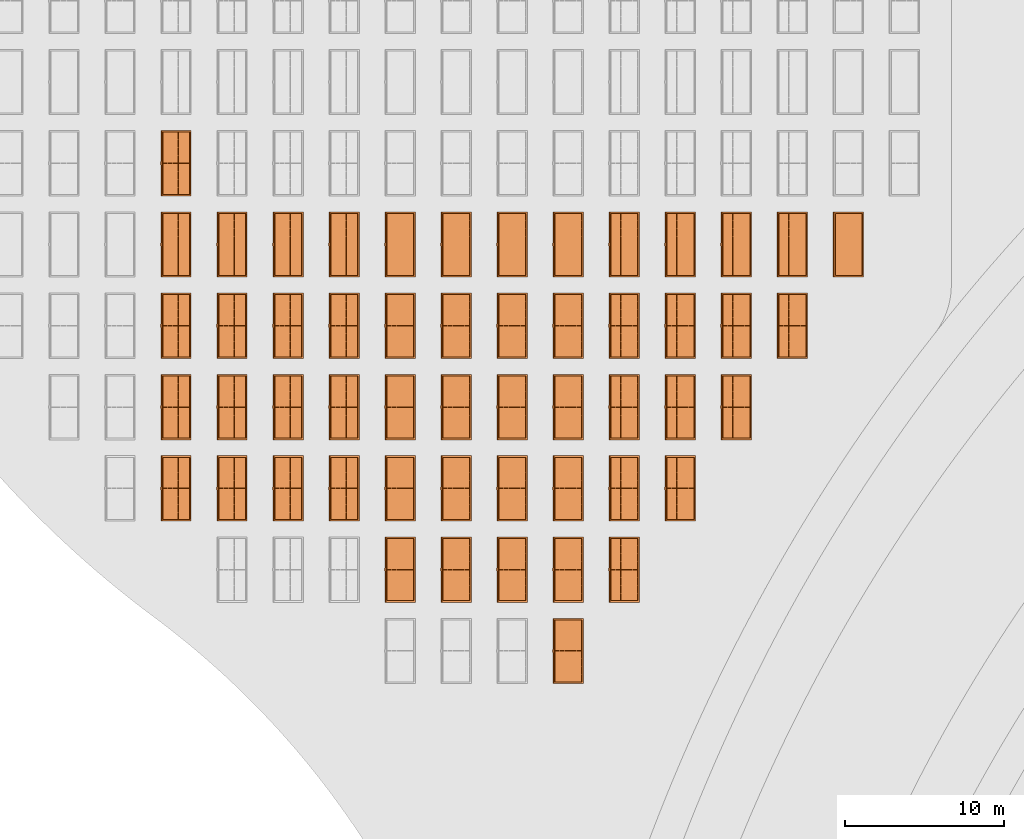
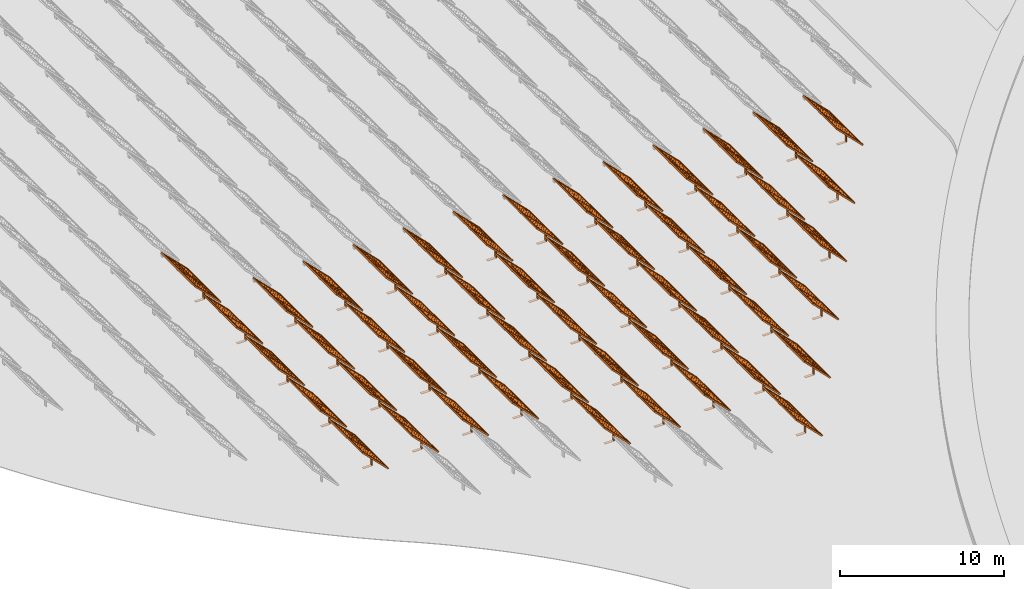
# One storey, part 16 of 39: 53 proxies.
"""IFC2X3 building model written with IfcOpenShell, lengths in millimetres."""

from ifc_helpers import new_model, entity, si_unit, converted_unit, derived_unit, direction, frame, frame_2d, origin, origin_2d_with_axis, place, context, subcontext, project, spatial, polyline, rectangle, outline, extrude, source, transform, mapped, material, material_list, element, save


model = new_model("IFC2X3")

# Units and contexts
model_context = context("Model", 3, precision=1e-06, world=origin(), true_north=direction((2.0, 6.12303176911189e-17, 1.0)))
context_of_model = context(None, 3, precision=1e-06, world=origin(), true_north=direction((2.0, 6.12303176911189e-17, 1.0)))
body_context = subcontext(model_context, "Body", "Model", "MODEL_VIEW")
ifc_project = project(units=[si_unit("LENGTHUNIT", "METRE", prefix="MILLI"), si_unit("AREAUNIT", "SQUARE_METRE", prefix="MILLI"), si_unit("VOLUMEUNIT", "CUBIC_METRE", prefix="MILLI"), converted_unit("PLANEANGLEUNIT", "DEGREE", entity("IfcRatioMeasure", 0.0174532925199433), si_unit("PLANEANGLEUNIT", "RADIAN"), dimensions=[0, 0, 0, 0, 0, 0, 0]), si_unit("MASSUNIT", "GRAM", prefix="KILO"), si_unit("TIMEUNIT", "SECOND"), si_unit("THERMODYNAMICTEMPERATUREUNIT", "KELVIN"), derived_unit("THERMALTRANSMITTANCEUNIT", [(si_unit("MASSUNIT", "GRAM", prefix="KILO"), 1), (si_unit("THERMODYNAMICTEMPERATUREUNIT", "KELVIN"), -1), (si_unit("TIMEUNIT", "SECOND"), -3)]), derived_unit("VOLUMETRICFLOWRATEUNIT", [(si_unit("LENGTHUNIT", "METRE"), 3), (si_unit("TIMEUNIT", "SECOND"), -1)])], contexts=[model_context, context_of_model])

# Site, building, storey
site_placement = place(None, origin())
site = spatial("IfcSite", under=ifc_project, at=site_placement, CompositionType="ELEMENT")
building_placement = place(site_placement, origin())
building = spatial("IfcBuilding", under=site, at=building_placement, CompositionType="ELEMENT")
storey_placement = place(building_placement, frame((0.0, 0.0, 4000.0)))
storey = spatial("IfcBuildingStorey", under=building, at=storey_placement, Name="Level 2", CompositionType="ELEMENT", Elevation=4000.0)

# Proxies
ifc_material_1 = material(Name="Stand-Steel")
ifc_material_2 = material(Name="Aluminium")
ifc_material_3 = material(Name="Glass")
ifc_material_list_1 = material_list([ifc_material_1, ifc_material_2, ifc_material_3])
shared_shape = source(origin(), body_context, "Body", "SweptSolid", [
    extrude(outline(polyline([(-629.526235435404, -220.0), (329.763117717702, -220.0), (329.763117717703, 410.0), (299.763117717703, 410.0), (299.763117717702, -190.0), (-629.526235435404, -190.0), (-629.526235435404, -220.0)])), frame((-190.00003127179, -100.0, 299.763117717707), z_axis=(0.0, 1.0, 0.0), x_axis=(0.0, 0.0, -1.0)), (0.0, 0.0, 1.0), 200.0),
    extrude(rectangle(XDim=20.0000000000001, YDim=200.0, at=frame_2d((0.0, -7.105427357601e-14), x_axis=(0.0, 1.0))), frame((-7.07109908365613, 0.0, 922.21828534124), z_axis=(-0.70710678118654, 0.0, 0.707106781186555), x_axis=(0.0, 1.0, 0.0)), (0.0, 0.0, 1.0), 2600.0),
    extrude(rectangle(XDim=24.9999999999997, YDim=24.9999999999999, at=frame_2d((2.87769807982841e-13, -9.50350909079134e-14), x_axis=(1.0, 0.0))), frame((-1449.56292018118, -1950.0, 2449.57494522722), z_axis=(0.0, 1.0, 0.0), x_axis=(-0.707106781186548, 0.0, -0.707106781186548)), (0.0, 0.0, 1.0), 3900.0),
    extrude(rectangle(XDim=24.9999999999999, YDim=25.0000000000001, at=origin_2d_with_axis()), frame((-1096.0095295879, -1950.0, 2096.02155463395), z_axis=(0.0, 1.0, 0.0), x_axis=(-0.707106781186542, 0.0, -0.707106781186553)), (0.0, 0.0, 1.0), 3900.0),
    extrude(rectangle(XDim=24.9999999999999, YDim=25.0000000000001, at=origin_2d_with_axis()), frame((-742.456138994631, -1950.0, 1742.46816404067), z_axis=(0.0, 1.0, 0.0), x_axis=(-0.707106781186542, 0.0, -0.707106781186553)), (0.0, 0.0, 1.0), 3900.0),
    extrude(rectangle(XDim=25.0, YDim=24.9999999999997, at=frame_2d((-7.19424519957101e-14, 1.19904086659517e-13), x_axis=(1.0, 0.0))), frame((-388.902748401358, -1950.0, 1388.9147734474), z_axis=(0.0, 1.0, 0.0), x_axis=(-0.707106781186545, 0.0, -0.70710678118655)), (0.0, 0.0, 1.0), 3900.0),
    extrude(rectangle(XDim=25.0000000000002, YDim=25.0, at=frame_2d((1.35891298214119e-13, 6.21724893790088e-15), x_axis=(0.0, 1.0))), frame((-35.3553703311048, 1500.0, 1035.35537033109), z_axis=(-0.707106781186544, 0.0, 0.707106781186551), x_axis=(0.0, 1.0, 0.0)), (0.0, 0.0, 1.0), 2440.0),
    extrude(rectangle(XDim=25.0000000000002, YDim=25.0, at=frame_2d((0.0, 1.77635683940025e-15), x_axis=(0.0, 1.0))), frame((-35.3553703311059, 1000.0, 1035.35537033109), z_axis=(-0.707106781186546, 0.0, 0.707106781186549), x_axis=(0.0, 1.0, 0.0)), (0.0, 0.0, 1.0), 2440.0),
    extrude(rectangle(XDim=25.0000000000002, YDim=25.0, at=frame_2d((0.0, 8.43769498715119e-14), x_axis=(0.0, 1.0))), frame((-26.5165355662756, 0.0, 1044.19420509593), z_axis=(-0.707106781186546, 0.0, 0.707106781186549), x_axis=(0.0, -1.0, 0.0)), (0.0, 0.0, 1.0), 2440.0),
    extrude(rectangle(XDim=25.0000000000002, YDim=25.0, at=frame_2d((0.0, 8.88178419700125e-16), x_axis=(0.0, 1.0))), frame((-35.3553703311065, 500.0, 1035.35537033109), z_axis=(-0.707106781186546, 0.0, 0.707106781186549), x_axis=(0.0, 1.0, 0.0)), (0.0, 0.0, 1.0), 2440.0),
    extrude(rectangle(XDim=25.0000000000002, YDim=25.0, at=frame_2d((0.0, 8.88178419700125e-16), x_axis=(0.0, 1.0))), frame((-35.3553703311086, -500.0, 1035.35537033109), z_axis=(-0.707106781186546, 0.0, 0.707106781186549), x_axis=(0.0, 1.0, 0.0)), (0.0, 0.0, 1.0), 2440.0),
    extrude(rectangle(XDim=25.0000000000002, YDim=25.0, at=frame_2d((0.0, 8.88178419700125e-16), x_axis=(0.0, 1.0))), frame((-35.3553703311095, -1000.0, 1035.35537033109), z_axis=(-0.707106781186546, 0.0, 0.707106781186549), x_axis=(0.0, 1.0, 0.0)), (0.0, 0.0, 1.0), 2440.0),
    extrude(rectangle(XDim=25.0000000000002, YDim=25.0, at=frame_2d((1.35891298214119e-13, 1.77635683940025e-15), x_axis=(0.0, 1.0))), frame((-35.3553703311107, -1500.0, 1035.35537033109), z_axis=(-0.707106781186546, 0.0, 0.707106781186549), x_axis=(0.0, 1.0, 0.0)), (0.0, 0.0, 1.0), 2440.0),
    extrude(rectangle(XDim=2400.0, YDim=11.9999999999994, at=frame_2d((-1.13686837721616e-13, 2.02948768901479e-13), x_axis=(1.0, 0.0))), frame((-883.883507754966, -1950.0, 1883.88350775495), z_axis=(0.0, 1.0, 0.0), x_axis=(0.707106781186546, 0.0, -0.707106781186549)), (0.0, 0.0, 1.0), 3900.0),
    extrude(outline(polyline([(-2050.0, -1300.0), (2050.0, -1300.0), (2050.0, 1300.0), (-2050.0, 1300.0), (-2050.0, -1300.0)]), holes=[polyline([(1950.0, -1200.0), (-1950.0, -1200.0), (-1950.0, 1200.0), (1950.0, 1200.0), (1950.0, -1200.0)])]), frame((-919.238846814293, 0.0, 1848.52816869563), z_axis=(0.707106781186554, 0.0, 0.707106781186541), x_axis=(0.0, 1.0, 0.0)), (0.0, 0.0, 1.0), 99.9999999999898),
])
proxy_1_placement = place(storey_placement, frame((-205580.32831183, 469944.680552409, 30.0)))
element("IfcBuildingElementProxy", 1, at=proxy_1_placement, inside=storey, material=ifc_material_list_1, Name="Solar Panel_4000X2500:Solar Panel_4000X2500", ObjectType="Solar Panel_4000X2500", CompositionType="ELEMENT", context=body_context, shape_type="MappedRepresentation", body=[
    mapped(shared_shape, transform((0.0, 0.0, 0.0), scale=1.0)),
])
ifc_material_list_2 = material_list([ifc_material_1, ifc_material_2, ifc_material_3])
proxy_2_placement = place(storey_placement, frame((-163400.32831183, 464844.680552409, 30.0)))
element("IfcBuildingElementProxy", 2, at=proxy_2_placement, inside=storey, material=ifc_material_list_2, Name="Solar Panel_4000X2500:Solar Panel_4000X2500", ObjectType="Solar Panel_4000X2500", CompositionType="ELEMENT", context=body_context, shape_type="MappedRepresentation", body=[
    mapped(shared_shape, transform((0.0, 0.0, 0.0), scale=1.0)),
])
ifc_material_list_3 = material_list([ifc_material_1, ifc_material_2, ifc_material_3])
proxy_3_placement = place(storey_placement, frame((-166915.32831183, 464844.680552409, 30.0)))
element("IfcBuildingElementProxy", 3, at=proxy_3_placement, inside=storey, material=ifc_material_list_3, Name="Solar Panel_4000X2500:Solar Panel_4000X2500", ObjectType="Solar Panel_4000X2500", CompositionType="ELEMENT", context=body_context, shape_type="MappedRepresentation", body=[
    mapped(shared_shape, transform((0.0, 0.0, 0.0), scale=1.0)),
])
ifc_material_list_4 = material_list([ifc_material_1, ifc_material_2, ifc_material_3])
proxy_4_placement = place(storey_placement, frame((-170430.32831183, 464844.680552409, 30.0)))
element("IfcBuildingElementProxy", 4, at=proxy_4_placement, inside=storey, material=ifc_material_list_4, Name="Solar Panel_4000X2500:Solar Panel_4000X2500", ObjectType="Solar Panel_4000X2500", CompositionType="ELEMENT", context=body_context, shape_type="MappedRepresentation", body=[
    mapped(shared_shape, transform((0.0, 0.0, 0.0), scale=1.0)),
])
ifc_material_list_5 = material_list([ifc_material_1, ifc_material_2, ifc_material_3])
proxy_5_placement = place(storey_placement, frame((-173945.32831183, 464844.680552409, 30.0)))
element("IfcBuildingElementProxy", 5, at=proxy_5_placement, inside=storey, material=ifc_material_list_5, Name="Solar Panel_4000X2500:Solar Panel_4000X2500", ObjectType="Solar Panel_4000X2500", CompositionType="ELEMENT", context=body_context, shape_type="MappedRepresentation", body=[
    mapped(shared_shape, transform((0.0, 0.0, 0.0), scale=1.0)),
])
ifc_material_list_6 = material_list([ifc_material_1, ifc_material_2, ifc_material_3])
proxy_6_placement = place(storey_placement, frame((-177460.32831183, 464844.680552409, 30.0)))
element("IfcBuildingElementProxy", 6, at=proxy_6_placement, inside=storey, material=ifc_material_list_6, Name="Solar Panel_4000X2500:Solar Panel_4000X2500", ObjectType="Solar Panel_4000X2500", CompositionType="ELEMENT", context=body_context, shape_type="MappedRepresentation", body=[
    mapped(shared_shape, transform((0.0, 0.0, 0.0), scale=1.0)),
])
ifc_material_list_7 = material_list([ifc_material_1, ifc_material_2, ifc_material_3])
proxy_7_placement = place(storey_placement, frame((-180975.32831183, 464844.680552409, 30.0)))
element("IfcBuildingElementProxy", 7, at=proxy_7_placement, inside=storey, material=ifc_material_list_7, Name="Solar Panel_4000X2500:Solar Panel_4000X2500", ObjectType="Solar Panel_4000X2500", CompositionType="ELEMENT", context=body_context, shape_type="MappedRepresentation", body=[
    mapped(shared_shape, transform((0.0, 0.0, 0.0), scale=1.0)),
])
ifc_material_list_8 = material_list([ifc_material_1, ifc_material_2, ifc_material_3])
proxy_8_placement = place(storey_placement, frame((-184490.32831183, 464844.680552409, 30.0)))
element("IfcBuildingElementProxy", 8, at=proxy_8_placement, inside=storey, material=ifc_material_list_8, Name="Solar Panel_4000X2500:Solar Panel_4000X2500", ObjectType="Solar Panel_4000X2500", CompositionType="ELEMENT", context=body_context, shape_type="MappedRepresentation", body=[
    mapped(shared_shape, transform((0.0, 0.0, 0.0), scale=1.0)),
])
ifc_material_list_9 = material_list([ifc_material_1, ifc_material_2, ifc_material_3])
proxy_9_placement = place(storey_placement, frame((-188005.32831183, 464844.680552409, 30.0)))
element("IfcBuildingElementProxy", 9, at=proxy_9_placement, inside=storey, material=ifc_material_list_9, Name="Solar Panel_4000X2500:Solar Panel_4000X2500", ObjectType="Solar Panel_4000X2500", CompositionType="ELEMENT", context=body_context, shape_type="MappedRepresentation", body=[
    mapped(shared_shape, transform((0.0, 0.0, 0.0), scale=1.0)),
])
ifc_material_list_10 = material_list([ifc_material_1, ifc_material_2, ifc_material_3])
proxy_10_placement = place(storey_placement, frame((-191520.32831183, 464844.680552409, 30.0)))
element("IfcBuildingElementProxy", 10, at=proxy_10_placement, inside=storey, material=ifc_material_list_10, Name="Solar Panel_4000X2500:Solar Panel_4000X2500", ObjectType="Solar Panel_4000X2500", CompositionType="ELEMENT", context=body_context, shape_type="MappedRepresentation", body=[
    mapped(shared_shape, transform((0.0, 0.0, 0.0), scale=1.0)),
])
ifc_material_list_11 = material_list([ifc_material_1, ifc_material_2, ifc_material_3])
proxy_11_placement = place(storey_placement, frame((-195035.32831183, 464844.680552409, 30.0)))
element("IfcBuildingElementProxy", 11, at=proxy_11_placement, inside=storey, material=ifc_material_list_11, Name="Solar Panel_4000X2500:Solar Panel_4000X2500", ObjectType="Solar Panel_4000X2500", CompositionType="ELEMENT", context=body_context, shape_type="MappedRepresentation", body=[
    mapped(shared_shape, transform((0.0, 0.0, 0.0), scale=1.0)),
])
ifc_material_list_12 = material_list([ifc_material_1, ifc_material_2, ifc_material_3])
proxy_12_placement = place(storey_placement, frame((-198550.32831183, 464844.680552409, 30.0)))
element("IfcBuildingElementProxy", 12, at=proxy_12_placement, inside=storey, material=ifc_material_list_12, Name="Solar Panel_4000X2500:Solar Panel_4000X2500", ObjectType="Solar Panel_4000X2500", CompositionType="ELEMENT", context=body_context, shape_type="MappedRepresentation", body=[
    mapped(shared_shape, transform((0.0, 0.0, 0.0), scale=1.0)),
])
ifc_material_list_13 = material_list([ifc_material_1, ifc_material_2, ifc_material_3])
proxy_13_placement = place(storey_placement, frame((-202065.32831183, 464844.680552409, 30.0)))
element("IfcBuildingElementProxy", 13, at=proxy_13_placement, inside=storey, material=ifc_material_list_13, Name="Solar Panel_4000X2500:Solar Panel_4000X2500", ObjectType="Solar Panel_4000X2500", CompositionType="ELEMENT", context=body_context, shape_type="MappedRepresentation", body=[
    mapped(shared_shape, transform((0.0, 0.0, 0.0), scale=1.0)),
])
ifc_material_list_14 = material_list([ifc_material_1, ifc_material_2, ifc_material_3])
proxy_14_placement = place(storey_placement, frame((-205580.32831183, 464844.680552409, 30.0)))
element("IfcBuildingElementProxy", 14, at=proxy_14_placement, inside=storey, material=ifc_material_list_14, Name="Solar Panel_4000X2500:Solar Panel_4000X2500", ObjectType="Solar Panel_4000X2500", CompositionType="ELEMENT", context=body_context, shape_type="MappedRepresentation", body=[
    mapped(shared_shape, transform((0.0, 0.0, 0.0), scale=1.0)),
])
ifc_material_list_15 = material_list([ifc_material_1, ifc_material_2, ifc_material_3])
proxy_15_placement = place(storey_placement, frame((-166915.32831183, 459744.680552409, 30.0)))
element("IfcBuildingElementProxy", 15, at=proxy_15_placement, inside=storey, material=ifc_material_list_15, Name="Solar Panel_4000X2500:Solar Panel_4000X2500", ObjectType="Solar Panel_4000X2500", CompositionType="ELEMENT", context=body_context, shape_type="MappedRepresentation", body=[
    mapped(shared_shape, transform((0.0, 0.0, 0.0), scale=1.0)),
])
ifc_material_list_16 = material_list([ifc_material_1, ifc_material_2, ifc_material_3])
proxy_16_placement = place(storey_placement, frame((-170430.32831183, 459744.680552409, 30.0)))
element("IfcBuildingElementProxy", 16, at=proxy_16_placement, inside=storey, material=ifc_material_list_16, Name="Solar Panel_4000X2500:Solar Panel_4000X2500", ObjectType="Solar Panel_4000X2500", CompositionType="ELEMENT", context=body_context, shape_type="MappedRepresentation", body=[
    mapped(shared_shape, transform((0.0, 0.0, 0.0), scale=1.0)),
])
ifc_material_list_17 = material_list([ifc_material_1, ifc_material_2, ifc_material_3])
proxy_17_placement = place(storey_placement, frame((-173945.32831183, 459744.680552409, 30.0)))
element("IfcBuildingElementProxy", 17, at=proxy_17_placement, inside=storey, material=ifc_material_list_17, Name="Solar Panel_4000X2500:Solar Panel_4000X2500", ObjectType="Solar Panel_4000X2500", CompositionType="ELEMENT", context=body_context, shape_type="MappedRepresentation", body=[
    mapped(shared_shape, transform((0.0, 0.0, 0.0), scale=1.0)),
])
ifc_material_list_18 = material_list([ifc_material_1, ifc_material_2, ifc_material_3])
proxy_18_placement = place(storey_placement, frame((-177460.32831183, 459744.680552409, 30.0)))
element("IfcBuildingElementProxy", 18, at=proxy_18_placement, inside=storey, material=ifc_material_list_18, Name="Solar Panel_4000X2500:Solar Panel_4000X2500", ObjectType="Solar Panel_4000X2500", CompositionType="ELEMENT", context=body_context, shape_type="MappedRepresentation", body=[
    mapped(shared_shape, transform((0.0, 0.0, 0.0), scale=1.0)),
])
ifc_material_list_19 = material_list([ifc_material_1, ifc_material_2, ifc_material_3])
proxy_19_placement = place(storey_placement, frame((-180975.32831183, 459744.680552409, 30.0)))
element("IfcBuildingElementProxy", 19, at=proxy_19_placement, inside=storey, material=ifc_material_list_19, Name="Solar Panel_4000X2500:Solar Panel_4000X2500", ObjectType="Solar Panel_4000X2500", CompositionType="ELEMENT", context=body_context, shape_type="MappedRepresentation", body=[
    mapped(shared_shape, transform((0.0, 0.0, 0.0), scale=1.0)),
])
ifc_material_list_20 = material_list([ifc_material_1, ifc_material_2, ifc_material_3])
proxy_20_placement = place(storey_placement, frame((-184490.32831183, 459744.680552409, 30.0)))
element("IfcBuildingElementProxy", 20, at=proxy_20_placement, inside=storey, material=ifc_material_list_20, Name="Solar Panel_4000X2500:Solar Panel_4000X2500", ObjectType="Solar Panel_4000X2500", CompositionType="ELEMENT", context=body_context, shape_type="MappedRepresentation", body=[
    mapped(shared_shape, transform((0.0, 0.0, 0.0), scale=1.0)),
])
ifc_material_list_21 = material_list([ifc_material_1, ifc_material_2, ifc_material_3])
proxy_21_placement = place(storey_placement, frame((-188005.32831183, 459744.680552409, 30.0)))
element("IfcBuildingElementProxy", 21, at=proxy_21_placement, inside=storey, material=ifc_material_list_21, Name="Solar Panel_4000X2500:Solar Panel_4000X2500", ObjectType="Solar Panel_4000X2500", CompositionType="ELEMENT", context=body_context, shape_type="MappedRepresentation", body=[
    mapped(shared_shape, transform((0.0, 0.0, 0.0), scale=1.0)),
])
ifc_material_list_22 = material_list([ifc_material_1, ifc_material_2, ifc_material_3])
proxy_22_placement = place(storey_placement, frame((-191520.32831183, 459744.680552409, 30.0)))
element("IfcBuildingElementProxy", 22, at=proxy_22_placement, inside=storey, material=ifc_material_list_22, Name="Solar Panel_4000X2500:Solar Panel_4000X2500", ObjectType="Solar Panel_4000X2500", CompositionType="ELEMENT", context=body_context, shape_type="MappedRepresentation", body=[
    mapped(shared_shape, transform((0.0, 0.0, 0.0), scale=1.0)),
])
ifc_material_list_23 = material_list([ifc_material_1, ifc_material_2, ifc_material_3])
proxy_23_placement = place(storey_placement, frame((-195035.32831183, 459744.680552409, 30.0)))
element("IfcBuildingElementProxy", 23, at=proxy_23_placement, inside=storey, material=ifc_material_list_23, Name="Solar Panel_4000X2500:Solar Panel_4000X2500", ObjectType="Solar Panel_4000X2500", CompositionType="ELEMENT", context=body_context, shape_type="MappedRepresentation", body=[
    mapped(shared_shape, transform((0.0, 0.0, 0.0), scale=1.0)),
])
ifc_material_list_24 = material_list([ifc_material_1, ifc_material_2, ifc_material_3])
proxy_24_placement = place(storey_placement, frame((-198550.32831183, 459744.680552409, 30.0)))
element("IfcBuildingElementProxy", 24, at=proxy_24_placement, inside=storey, material=ifc_material_list_24, Name="Solar Panel_4000X2500:Solar Panel_4000X2500", ObjectType="Solar Panel_4000X2500", CompositionType="ELEMENT", context=body_context, shape_type="MappedRepresentation", body=[
    mapped(shared_shape, transform((0.0, 0.0, 0.0), scale=1.0)),
])
ifc_material_list_25 = material_list([ifc_material_1, ifc_material_2, ifc_material_3])
proxy_25_placement = place(storey_placement, frame((-202065.32831183, 459744.680552409, 30.0)))
element("IfcBuildingElementProxy", 25, at=proxy_25_placement, inside=storey, material=ifc_material_list_25, Name="Solar Panel_4000X2500:Solar Panel_4000X2500", ObjectType="Solar Panel_4000X2500", CompositionType="ELEMENT", context=body_context, shape_type="MappedRepresentation", body=[
    mapped(shared_shape, transform((0.0, 0.0, 0.0), scale=1.0)),
])
ifc_material_list_26 = material_list([ifc_material_1, ifc_material_2, ifc_material_3])
proxy_26_placement = place(storey_placement, frame((-205580.32831183, 459744.680552409, 30.0)))
element("IfcBuildingElementProxy", 26, at=proxy_26_placement, inside=storey, material=ifc_material_list_26, Name="Solar Panel_4000X2500:Solar Panel_4000X2500", ObjectType="Solar Panel_4000X2500", CompositionType="ELEMENT", context=body_context, shape_type="MappedRepresentation", body=[
    mapped(shared_shape, transform((0.0, 0.0, 0.0), scale=1.0)),
])
ifc_material_list_27 = material_list([ifc_material_1, ifc_material_2, ifc_material_3])
proxy_27_placement = place(storey_placement, frame((-170430.32831183, 454644.680552409, 30.0)))
element("IfcBuildingElementProxy", 27, at=proxy_27_placement, inside=storey, material=ifc_material_list_27, Name="Solar Panel_4000X2500:Solar Panel_4000X2500", ObjectType="Solar Panel_4000X2500", CompositionType="ELEMENT", context=body_context, shape_type="MappedRepresentation", body=[
    mapped(shared_shape, transform((0.0, 0.0, 0.0), scale=1.0)),
])
ifc_material_list_28 = material_list([ifc_material_1, ifc_material_2, ifc_material_3])
proxy_28_placement = place(storey_placement, frame((-173945.32831183, 454644.680552409, 30.0)))
element("IfcBuildingElementProxy", 28, at=proxy_28_placement, inside=storey, material=ifc_material_list_28, Name="Solar Panel_4000X2500:Solar Panel_4000X2500", ObjectType="Solar Panel_4000X2500", CompositionType="ELEMENT", context=body_context, shape_type="MappedRepresentation", body=[
    mapped(shared_shape, transform((0.0, 0.0, 0.0), scale=1.0)),
])
ifc_material_list_29 = material_list([ifc_material_1, ifc_material_2, ifc_material_3])
proxy_29_placement = place(storey_placement, frame((-177460.32831183, 454644.680552409, 30.0)))
element("IfcBuildingElementProxy", 29, at=proxy_29_placement, inside=storey, material=ifc_material_list_29, Name="Solar Panel_4000X2500:Solar Panel_4000X2500", ObjectType="Solar Panel_4000X2500", CompositionType="ELEMENT", context=body_context, shape_type="MappedRepresentation", body=[
    mapped(shared_shape, transform((0.0, 0.0, 0.0), scale=1.0)),
])
ifc_material_list_30 = material_list([ifc_material_1, ifc_material_2, ifc_material_3])
proxy_30_placement = place(storey_placement, frame((-180975.32831183, 454644.680552409, 30.0)))
element("IfcBuildingElementProxy", 30, at=proxy_30_placement, inside=storey, material=ifc_material_list_30, Name="Solar Panel_4000X2500:Solar Panel_4000X2500", ObjectType="Solar Panel_4000X2500", CompositionType="ELEMENT", context=body_context, shape_type="MappedRepresentation", body=[
    mapped(shared_shape, transform((0.0, 0.0, 0.0), scale=1.0)),
])
ifc_material_list_31 = material_list([ifc_material_1, ifc_material_2, ifc_material_3])
proxy_31_placement = place(storey_placement, frame((-184490.32831183, 454644.680552409, 30.0)))
element("IfcBuildingElementProxy", 31, at=proxy_31_placement, inside=storey, material=ifc_material_list_31, Name="Solar Panel_4000X2500:Solar Panel_4000X2500", ObjectType="Solar Panel_4000X2500", CompositionType="ELEMENT", context=body_context, shape_type="MappedRepresentation", body=[
    mapped(shared_shape, transform((0.0, 0.0, 0.0), scale=1.0)),
])
ifc_material_list_32 = material_list([ifc_material_1, ifc_material_2, ifc_material_3])
proxy_32_placement = place(storey_placement, frame((-188005.32831183, 454644.680552409, 30.0)))
element("IfcBuildingElementProxy", 32, at=proxy_32_placement, inside=storey, material=ifc_material_list_32, Name="Solar Panel_4000X2500:Solar Panel_4000X2500", ObjectType="Solar Panel_4000X2500", CompositionType="ELEMENT", context=body_context, shape_type="MappedRepresentation", body=[
    mapped(shared_shape, transform((0.0, 0.0, 0.0), scale=1.0)),
])
ifc_material_list_33 = material_list([ifc_material_1, ifc_material_2, ifc_material_3])
proxy_33_placement = place(storey_placement, frame((-191520.32831183, 454644.680552409, 30.0)))
element("IfcBuildingElementProxy", 33, at=proxy_33_placement, inside=storey, material=ifc_material_list_33, Name="Solar Panel_4000X2500:Solar Panel_4000X2500", ObjectType="Solar Panel_4000X2500", CompositionType="ELEMENT", context=body_context, shape_type="MappedRepresentation", body=[
    mapped(shared_shape, transform((0.0, 0.0, 0.0), scale=1.0)),
])
ifc_material_list_34 = material_list([ifc_material_1, ifc_material_2, ifc_material_3])
proxy_34_placement = place(storey_placement, frame((-195035.32831183, 454644.680552409, 30.0)))
element("IfcBuildingElementProxy", 34, at=proxy_34_placement, inside=storey, material=ifc_material_list_34, Name="Solar Panel_4000X2500:Solar Panel_4000X2500", ObjectType="Solar Panel_4000X2500", CompositionType="ELEMENT", context=body_context, shape_type="MappedRepresentation", body=[
    mapped(shared_shape, transform((0.0, 0.0, 0.0), scale=1.0)),
])
ifc_material_list_35 = material_list([ifc_material_1, ifc_material_2, ifc_material_3])
proxy_35_placement = place(storey_placement, frame((-198550.32831183, 454644.680552409, 30.0)))
element("IfcBuildingElementProxy", 35, at=proxy_35_placement, inside=storey, material=ifc_material_list_35, Name="Solar Panel_4000X2500:Solar Panel_4000X2500", ObjectType="Solar Panel_4000X2500", CompositionType="ELEMENT", context=body_context, shape_type="MappedRepresentation", body=[
    mapped(shared_shape, transform((0.0, 0.0, 0.0), scale=1.0)),
])
ifc_material_list_36 = material_list([ifc_material_1, ifc_material_2, ifc_material_3])
proxy_36_placement = place(storey_placement, frame((-202065.32831183, 454644.680552409, 30.0)))
element("IfcBuildingElementProxy", 36, at=proxy_36_placement, inside=storey, material=ifc_material_list_36, Name="Solar Panel_4000X2500:Solar Panel_4000X2500", ObjectType="Solar Panel_4000X2500", CompositionType="ELEMENT", context=body_context, shape_type="MappedRepresentation", body=[
    mapped(shared_shape, transform((0.0, 0.0, 0.0), scale=1.0)),
])
ifc_material_list_37 = material_list([ifc_material_1, ifc_material_2, ifc_material_3])
proxy_37_placement = place(storey_placement, frame((-205580.32831183, 454644.680552409, 30.0)))
element("IfcBuildingElementProxy", 37, at=proxy_37_placement, inside=storey, material=ifc_material_list_37, Name="Solar Panel_4000X2500:Solar Panel_4000X2500", ObjectType="Solar Panel_4000X2500", CompositionType="ELEMENT", context=body_context, shape_type="MappedRepresentation", body=[
    mapped(shared_shape, transform((0.0, 0.0, 0.0), scale=1.0)),
])
ifc_material_list_38 = material_list([ifc_material_1, ifc_material_2, ifc_material_3])
proxy_38_placement = place(storey_placement, frame((-173945.32831183, 449544.680552409, 30.0)))
element("IfcBuildingElementProxy", 38, at=proxy_38_placement, inside=storey, material=ifc_material_list_38, Name="Solar Panel_4000X2500:Solar Panel_4000X2500", ObjectType="Solar Panel_4000X2500", CompositionType="ELEMENT", context=body_context, shape_type="MappedRepresentation", body=[
    mapped(shared_shape, transform((0.0, 0.0, 0.0), scale=1.0)),
])
ifc_material_list_39 = material_list([ifc_material_1, ifc_material_2, ifc_material_3])
proxy_39_placement = place(storey_placement, frame((-177460.32831183, 449544.680552409, 30.0)))
element("IfcBuildingElementProxy", 39, at=proxy_39_placement, inside=storey, material=ifc_material_list_39, Name="Solar Panel_4000X2500:Solar Panel_4000X2500", ObjectType="Solar Panel_4000X2500", CompositionType="ELEMENT", context=body_context, shape_type="MappedRepresentation", body=[
    mapped(shared_shape, transform((0.0, 0.0, 0.0), scale=1.0)),
])
ifc_material_list_40 = material_list([ifc_material_1, ifc_material_2, ifc_material_3])
proxy_40_placement = place(storey_placement, frame((-180975.32831183, 449544.680552409, 30.0)))
element("IfcBuildingElementProxy", 40, at=proxy_40_placement, inside=storey, material=ifc_material_list_40, Name="Solar Panel_4000X2500:Solar Panel_4000X2500", ObjectType="Solar Panel_4000X2500", CompositionType="ELEMENT", context=body_context, shape_type="MappedRepresentation", body=[
    mapped(shared_shape, transform((0.0, 0.0, 0.0), scale=1.0)),
])
ifc_material_list_41 = material_list([ifc_material_1, ifc_material_2, ifc_material_3])
proxy_41_placement = place(storey_placement, frame((-184490.32831183, 449544.680552409, 30.0)))
element("IfcBuildingElementProxy", 41, at=proxy_41_placement, inside=storey, material=ifc_material_list_41, Name="Solar Panel_4000X2500:Solar Panel_4000X2500", ObjectType="Solar Panel_4000X2500", CompositionType="ELEMENT", context=body_context, shape_type="MappedRepresentation", body=[
    mapped(shared_shape, transform((0.0, 0.0, 0.0), scale=1.0)),
])
ifc_material_list_42 = material_list([ifc_material_1, ifc_material_2, ifc_material_3])
proxy_42_placement = place(storey_placement, frame((-188005.32831183, 449544.680552409, 30.0)))
element("IfcBuildingElementProxy", 42, at=proxy_42_placement, inside=storey, material=ifc_material_list_42, Name="Solar Panel_4000X2500:Solar Panel_4000X2500", ObjectType="Solar Panel_4000X2500", CompositionType="ELEMENT", context=body_context, shape_type="MappedRepresentation", body=[
    mapped(shared_shape, transform((0.0, 0.0, 0.0), scale=1.0)),
])
ifc_material_list_43 = material_list([ifc_material_1, ifc_material_2, ifc_material_3])
proxy_43_placement = place(storey_placement, frame((-191520.32831183, 449544.680552409, 30.0)))
element("IfcBuildingElementProxy", 43, at=proxy_43_placement, inside=storey, material=ifc_material_list_43, Name="Solar Panel_4000X2500:Solar Panel_4000X2500", ObjectType="Solar Panel_4000X2500", CompositionType="ELEMENT", context=body_context, shape_type="MappedRepresentation", body=[
    mapped(shared_shape, transform((0.0, 0.0, 0.0), scale=1.0)),
])
ifc_material_list_44 = material_list([ifc_material_1, ifc_material_2, ifc_material_3])
proxy_44_placement = place(storey_placement, frame((-195035.32831183, 449544.680552409, 30.0)))
element("IfcBuildingElementProxy", 44, at=proxy_44_placement, inside=storey, material=ifc_material_list_44, Name="Solar Panel_4000X2500:Solar Panel_4000X2500", ObjectType="Solar Panel_4000X2500", CompositionType="ELEMENT", context=body_context, shape_type="MappedRepresentation", body=[
    mapped(shared_shape, transform((0.0, 0.0, 0.0), scale=1.0)),
])
ifc_material_list_45 = material_list([ifc_material_1, ifc_material_2, ifc_material_3])
proxy_45_placement = place(storey_placement, frame((-198550.32831183, 449544.680552409, 30.0)))
element("IfcBuildingElementProxy", 45, at=proxy_45_placement, inside=storey, material=ifc_material_list_45, Name="Solar Panel_4000X2500:Solar Panel_4000X2500", ObjectType="Solar Panel_4000X2500", CompositionType="ELEMENT", context=body_context, shape_type="MappedRepresentation", body=[
    mapped(shared_shape, transform((0.0, 0.0, 0.0), scale=1.0)),
])
ifc_material_list_46 = material_list([ifc_material_1, ifc_material_2, ifc_material_3])
proxy_46_placement = place(storey_placement, frame((-202065.32831183, 449544.680552409, 30.0)))
element("IfcBuildingElementProxy", 46, at=proxy_46_placement, inside=storey, material=ifc_material_list_46, Name="Solar Panel_4000X2500:Solar Panel_4000X2500", ObjectType="Solar Panel_4000X2500", CompositionType="ELEMENT", context=body_context, shape_type="MappedRepresentation", body=[
    mapped(shared_shape, transform((0.0, 0.0, 0.0), scale=1.0)),
])
ifc_material_list_47 = material_list([ifc_material_1, ifc_material_2, ifc_material_3])
proxy_47_placement = place(storey_placement, frame((-205580.32831183, 449544.680552409, 30.0)))
element("IfcBuildingElementProxy", 47, at=proxy_47_placement, inside=storey, material=ifc_material_list_47, Name="Solar Panel_4000X2500:Solar Panel_4000X2500", ObjectType="Solar Panel_4000X2500", CompositionType="ELEMENT", context=body_context, shape_type="MappedRepresentation", body=[
    mapped(shared_shape, transform((0.0, 0.0, 0.0), scale=1.0)),
])
ifc_material_list_48 = material_list([ifc_material_1, ifc_material_2, ifc_material_3])
proxy_48_placement = place(storey_placement, frame((-177460.32831183, 444444.680552409, 30.0)))
element("IfcBuildingElementProxy", 48, at=proxy_48_placement, inside=storey, material=ifc_material_list_48, Name="Solar Panel_4000X2500:Solar Panel_4000X2500", ObjectType="Solar Panel_4000X2500", CompositionType="ELEMENT", context=body_context, shape_type="MappedRepresentation", body=[
    mapped(shared_shape, transform((0.0, 0.0, 0.0), scale=1.0)),
])
ifc_material_list_49 = material_list([ifc_material_1, ifc_material_2, ifc_material_3])
proxy_49_placement = place(storey_placement, frame((-180975.32831183, 444444.680552409, 30.0)))
element("IfcBuildingElementProxy", 49, at=proxy_49_placement, inside=storey, material=ifc_material_list_49, Name="Solar Panel_4000X2500:Solar Panel_4000X2500", ObjectType="Solar Panel_4000X2500", CompositionType="ELEMENT", context=body_context, shape_type="MappedRepresentation", body=[
    mapped(shared_shape, transform((0.0, 0.0, 0.0), scale=1.0)),
])
ifc_material_list_50 = material_list([ifc_material_1, ifc_material_2, ifc_material_3])
proxy_50_placement = place(storey_placement, frame((-184490.32831183, 444444.680552409, 30.0)))
element("IfcBuildingElementProxy", 50, at=proxy_50_placement, inside=storey, material=ifc_material_list_50, Name="Solar Panel_4000X2500:Solar Panel_4000X2500", ObjectType="Solar Panel_4000X2500", CompositionType="ELEMENT", context=body_context, shape_type="MappedRepresentation", body=[
    mapped(shared_shape, transform((0.0, 0.0, 0.0), scale=1.0)),
])
ifc_material_list_51 = material_list([ifc_material_1, ifc_material_2, ifc_material_3])
proxy_51_placement = place(storey_placement, frame((-188005.32831183, 444444.680552409, 30.0)))
element("IfcBuildingElementProxy", 51, at=proxy_51_placement, inside=storey, material=ifc_material_list_51, Name="Solar Panel_4000X2500:Solar Panel_4000X2500", ObjectType="Solar Panel_4000X2500", CompositionType="ELEMENT", context=body_context, shape_type="MappedRepresentation", body=[
    mapped(shared_shape, transform((0.0, 0.0, 0.0), scale=1.0)),
])
ifc_material_list_52 = material_list([ifc_material_1, ifc_material_2, ifc_material_3])
proxy_52_placement = place(storey_placement, frame((-191520.32831183, 444444.680552409, 30.0)))
element("IfcBuildingElementProxy", 52, at=proxy_52_placement, inside=storey, material=ifc_material_list_52, Name="Solar Panel_4000X2500:Solar Panel_4000X2500", ObjectType="Solar Panel_4000X2500", CompositionType="ELEMENT", context=body_context, shape_type="MappedRepresentation", body=[
    mapped(shared_shape, transform((0.0, 0.0, 0.0), scale=1.0)),
])
ifc_material_list_53 = material_list([ifc_material_1, ifc_material_2, ifc_material_3])
proxy_53_placement = place(storey_placement, frame((-180975.32831183, 439344.680552409, 30.0)))
element("IfcBuildingElementProxy", 53, at=proxy_53_placement, inside=storey, material=ifc_material_list_53, Name="Solar Panel_4000X2500:Solar Panel_4000X2500", ObjectType="Solar Panel_4000X2500", CompositionType="ELEMENT", context=body_context, shape_type="MappedRepresentation", body=[
    mapped(shared_shape, transform((0.0, 0.0, 0.0), scale=1.0)),
])

save(model, "model.ifc")
